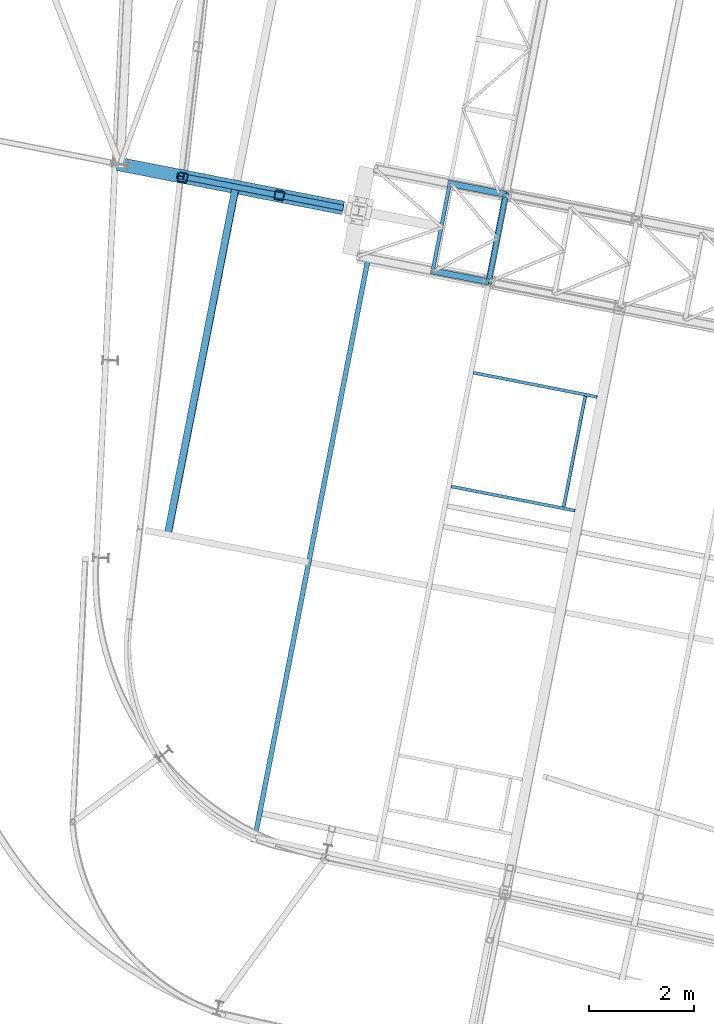
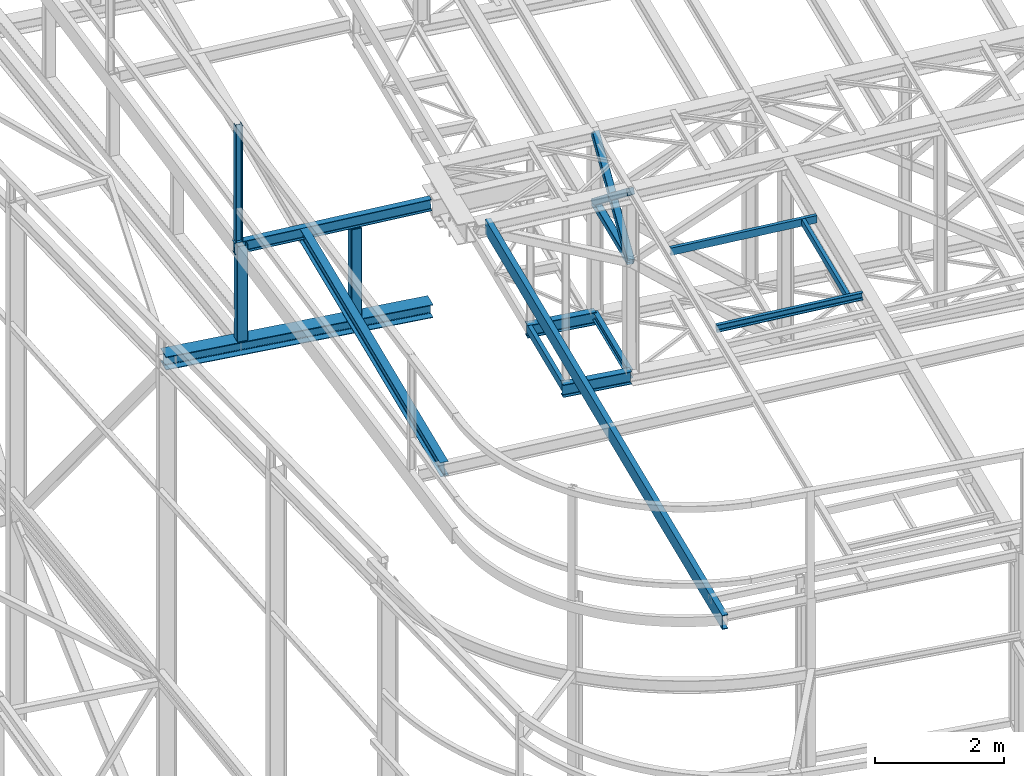
# One storey, part 40 of 215: 15 beams, 2 members, 17 elements without a shape of their own.
"""IFC2X3 building model written with IfcOpenShell, lengths in millimetres."""

from ifc_helpers import new_model, si_unit, frame, origin_with_axes, origin_2d_with_axis, place, context, subcontext, project, spatial, hollow_rectangle, i_section, u_section, extrude, material, type_object, element, aggregate, save


model = new_model("IFC2X3")

# Units and contexts
model_context = context("Model", 3, precision=1e-05, world=origin_with_axes())
body_context = subcontext(model_context, "Body", "Model", "MODEL_VIEW")
ifc_project = project(units=[si_unit("LENGTHUNIT", "METRE", prefix="MILLI"), si_unit("AREAUNIT", "SQUARE_METRE"), si_unit("VOLUMEUNIT", "CUBIC_METRE"), si_unit("MASSUNIT", "GRAM", prefix="KILO"), si_unit("TIMEUNIT", "SECOND"), si_unit("PLANEANGLEUNIT", "RADIAN"), si_unit("SOLIDANGLEUNIT", "STERADIAN"), si_unit("THERMODYNAMICTEMPERATUREUNIT", "DEGREE_CELSIUS"), si_unit("LUMINOUSINTENSITYUNIT", "LUMEN")], contexts=[model_context])

# Site, building, storey
site_placement = place(None, origin_with_axes())
site = spatial("IfcSite", under=ifc_project, at=site_placement, CompositionType="ELEMENT")
building_placement = place(site_placement, origin_with_axes())
building = spatial("IfcBuilding", under=site, at=building_placement, Name="Undefined", CompositionType="ELEMENT")
storey_placement = place(building_placement, origin_with_axes())
storey = spatial("IfcBuildingStorey", under=building, at=storey_placement, Name="Undefined", CompositionType="ELEMENT", Elevation=0.0)

# Assembly, beam
assembly_1_placement = place(storey_placement, origin_with_axes())
assembly_1 = element("IfcElementAssembly", 1, at=assembly_1_placement, inside=storey, Name="Steel Assembly", AssemblyPlace="NOTDEFINED", PredefinedType="RIGID_FRAME")
ifc_material_1 = material(Name="STEEL/S355JR")
beam_type_1 = type_object("IfcBeamType", Name="IPE240", PredefinedType="NOTDEFINED")
beam_1_placement = place(assembly_1_placement, frame((43625.947986334, 22043.2546402726, 8619.99999998952), z_axis=(0.0, 0.0, 1.0), x_axis=(0.981422409205525, -0.19185946604018, 1.89999991602007e-08)))
beam_1 = element("IfcBeam", 2, at=beam_1_placement, type_object=beam_type_1, material=ifc_material_1, ObjectType="IPE240", context=body_context, shape_type="SweptSolid", body=[
    extrude(i_section(OverallWidth=120.0, OverallDepth=240.0, WebThickness=6.199999809, FlangeThickness=9.800000191, FilletRadius=15.0, at=origin_2d_with_axis()), frame((1125.81204536132, 0.0, 0.0), z_axis=(-1.0, 0.0, 0.0), x_axis=(-6.93889390390723e-18, -1.0, -3.46944695195361e-18)), (0.0, 0.0, 1.0), 1125.8),
])
aggregate(assembly_1, [beam_1])

assembly_2_placement = place(storey_placement, origin_with_axes())
assembly_2 = element("IfcElementAssembly", 3, at=assembly_2_placement, inside=storey, Name="Steel Assembly", AssemblyPlace="NOTDEFINED", PredefinedType="RIGID_FRAME")
beam_2_placement = place(assembly_2_placement, frame((43952.1090785684, 23711.672735737, 8619.99999998888), z_axis=(0.0, 0.0, 1.0), x_axis=(0.981422409205525, -0.19185946604018, 1.89999991602007e-08)))
beam_2 = element("IfcBeam", 4, at=beam_2_placement, type_object=beam_type_1, material=ifc_material_1, ObjectType="IPE240", context=body_context, shape_type="SweptSolid", body=[
    extrude(i_section(OverallWidth=120.0, OverallDepth=240.0, WebThickness=6.199999809, FlangeThickness=9.800000191, FilletRadius=15.0, at=origin_2d_with_axis()), frame((1125.81204536132, 0.0, 0.0), z_axis=(-1.0, 0.0, 0.0), x_axis=(-6.93889390390723e-18, -1.0, -3.46944695195361e-18)), (0.0, 0.0, 1.0), 1125.8),
])
aggregate(assembly_2, [beam_2])

assembly_3_placement = place(storey_placement, origin_with_axes())
assembly_3 = element("IfcElementAssembly", 5, at=assembly_3_placement, inside=storey, Name="Steel Assembly", AssemblyPlace="NOTDEFINED", PredefinedType="RIGID_FRAME")
ifc_material_2 = material(Name="STEEL/S275JR")
beam_type_2 = type_object("IfcBeamType", Name="IPE270", PredefinedType="NOTDEFINED")
beam_3_placement = place(assembly_3_placement, frame((38609.0961091975, 17004.7103981775, 11917.5885771464), z_axis=(-0.0304080349967745, 0.00594450299936818, 0.999519891893966), x_axis=(0.191859470081235, 0.981422408415534, 0.0)))
beam_3 = element("IfcBeam", 6, at=beam_3_placement, type_object=beam_type_2, material=ifc_material_2, ObjectType="IPE270", context=body_context, shape_type="SweptSolid", body=[
    extrude(i_section(OverallWidth=135.0, OverallDepth=270.0, WebThickness=6.599999905, FlangeThickness=10.19999981, FilletRadius=15.0, at=origin_2d_with_axis()), frame((6759.39459620189, -3.7406013864434e-13, -1.82762251039334e-12), z_axis=(-1.0, 0.0, 0.0), x_axis=(-6.93889390390723e-18, -1.0, -3.46944695195361e-18)), (0.0, 0.0, 1.0), 6759.4),
])
aggregate(assembly_3, [beam_3])

assembly_4_placement = place(storey_placement, origin_with_axes())
assembly_4 = element("IfcElementAssembly", 7, at=assembly_4_placement, inside=storey, Name="Steel Assembly", AssemblyPlace="NOTDEFINED", PredefinedType="RIGID_FRAME")
beam_type_3 = type_object("IfcBeamType", PredefinedType="NOTDEFINED")
beam_4_placement = place(assembly_4_placement, frame((44730.8447938511, 21827.2570213611, 10796.0000011512), z_axis=(0.981422364268518, -0.191859461052493, -0.000300197000082615), x_axis=(0.191859470081235, 0.981422408415534, 0.0)))
beam_4 = element("IfcBeam", 8, at=beam_4_placement, type_object=beam_type_3, material=ifc_material_2, context=body_context, shape_type="SweptSolid", body=[
    extrude(hollow_rectangle(XDim=120.0, YDim=120.0, WallThickness=5.0, InnerFilletRadius=5.0, OuterFilletRadius=10.0, at=origin_2d_with_axis()), frame((1699.99999941724, 1.81898940354586e-12, 0.0), z_axis=(-1.0, 0.0, 0.0), x_axis=(-6.93889390390723e-18, -1.0, -3.46944695195361e-18)), (0.0, 0.0, 1.0), 1700.0),
])
aggregate(assembly_4, [beam_4])

assembly_5_placement = place(storey_placement, origin_with_axes())
assembly_5 = element("IfcElementAssembly", 9, at=assembly_5_placement, inside=storey, Name="Steel Assembly", AssemblyPlace="NOTDEFINED", PredefinedType="RIGID_FRAME")
ifc_material_3 = material(Name="STEEL/S235JR")
beam_type_4 = type_object("IfcBeamType", Name="UPN140", PredefinedType="NOTDEFINED")
beam_5_placement = place(assembly_5_placement, frame((46160.7311708302, 17536.3171577614, 12209.2147749676), z_axis=(-0.0304080349967745, 0.00594450299936818, 0.999519891893966), x_axis=(0.191879342079262, 0.981418523405397, 1.00000006478113e-09)))
beam_5 = element("IfcBeam", 10, at=beam_5_placement, type_object=beam_type_4, material=ifc_material_3, ObjectType="UPN140", context=body_context, shape_type="SweptSolid", body=[
    extrude(u_section(Depth=140.0, FlangeWidth=60.0, WebThickness=7.0, FlangeThickness=10.0, FilletRadius=10.0, EdgeRadius=5.0, FlangeSlope=0.0798299857122373, at=origin_2d_with_axis()), frame((2150.00349895753, 7.23853232835043e-12, -2.08044720554876e-15), z_axis=(-1.0, 0.0, 0.0), x_axis=(-6.93889390390723e-18, -1.0, -3.46944695195361e-18)), (0.0, 0.0, 1.0), 2150.0),
])
aggregate(assembly_5, [beam_5])

assembly_6_placement = place(storey_placement, origin_with_axes())
assembly_6 = element("IfcElementAssembly", 11, at=assembly_6_placement, inside=storey, Name="Steel Assembly", AssemblyPlace="NOTDEFINED", PredefinedType="RIGID_FRAME")
beam_6_placement = place(assembly_6_placement, frame((46798.1379311789, 19632.9744047019, 12216.1354340377), z_axis=(-0.0304080349967745, 0.00594450299936818, 0.999519891893966), x_axis=(-0.980947279001733, 0.191787511000338, -0.0309836480000548)))
beam_6 = element("IfcBeam", 12, at=beam_6_placement, type_object=beam_type_4, material=ifc_material_3, ObjectType="UPN140", context=body_context, shape_type="SweptSolid", body=[
    extrude(u_section(Depth=140.0, FlangeWidth=60.0, WebThickness=7.0, FlangeThickness=10.0, FilletRadius=10.0, EdgeRadius=5.0, FlangeSlope=0.0798299857122373, at=origin_2d_with_axis()), frame((2404.26612991932, -3.62067344519824e-12, -8.34147379613389e-15), z_axis=(-1.0, 0.0, 0.0), x_axis=(-6.93889390390723e-18, -1.0, -3.46944695195361e-18)), (0.0, 0.0, 1.0), 2404.3),
])
aggregate(assembly_6, [beam_6])

assembly_7_placement = place(storey_placement, origin_with_axes())
assembly_7 = element("IfcElementAssembly", 13, at=assembly_7_placement, inside=storey, Name="Steel Assembly", AssemblyPlace="NOTDEFINED", PredefinedType="RIGID_FRAME")
beam_7_placement = place(assembly_7_placement, frame((44015.7041884102, 17925.1288850211, 12141.6449800484), z_axis=(-0.0304080349967745, 0.00594450299936818, 0.999519891893966), x_axis=(0.9809472788136, -0.191787511963556, 0.0309836479941128)))
beam_7 = element("IfcBeam", 14, at=beam_7_placement, type_object=beam_type_4, material=ifc_material_3, ObjectType="UPN140", context=body_context, shape_type="SweptSolid", body=[
    extrude(u_section(Depth=140.0, FlangeWidth=60.0, WebThickness=7.0, FlangeThickness=10.0, FilletRadius=10.0, EdgeRadius=5.0, FlangeSlope=0.0798299857122373, at=origin_2d_with_axis()), frame((2404.26547487024, -4.76208710676447e-14, 1.81898940354586e-12), z_axis=(-1.0, 0.0, 0.0), x_axis=(-6.93889390390723e-18, -1.0, -3.46944695195361e-18)), (0.0, 0.0, 1.0), 2404.3),
])
aggregate(assembly_7, [beam_7])

# Assembly, member
assembly_8_placement = place(storey_placement, origin_with_axes())
assembly_8 = element("IfcElementAssembly", 15, at=assembly_8_placement, inside=storey, Name="Steel Assembly", AssemblyPlace="NOTDEFINED", PredefinedType="RIGID_FRAME")
member_type = type_object("IfcMemberType", PredefinedType="NOTDEFINED")
member_1_placement = place(assembly_8_placement, frame((45057.0058925501, 23495.6751151822, 10796.0000011494), z_axis=(0.981457773618154, -0.191678330925429, 0.000236765999907874), x_axis=(-0.15135681799229, -0.774238415960567, 0.614529078968702)))
member_1 = element("IfcMember", 16, at=member_1_placement, type_object=member_type, material=ifc_material_2, context=body_context, shape_type="SweptSolid", body=[
    extrude(hollow_rectangle(XDim=120.0, YDim=120.0, WallThickness=5.0, InnerFilletRadius=5.0, OuterFilletRadius=10.0, at=origin_2d_with_axis()), frame((2154.91514201782, 7.15633579384435e-12, 2.72186368544976e-14), z_axis=(-1.0, 0.0, 0.0), x_axis=(-6.93889390390723e-18, -1.0, -3.46944695195361e-18)), (0.0, 0.0, 1.0), 2154.9),
])
aggregate(assembly_8, [member_1])

assembly_9_placement = place(storey_placement, origin_with_axes())
assembly_9 = element("IfcElementAssembly", 17, at=assembly_9_placement, inside=storey, Name="Steel Assembly", AssemblyPlace="NOTDEFINED", PredefinedType="RIGID_FRAME")
member_2_placement = place(assembly_9_placement, frame((44730.8447938511, 21827.2570213611, 10796.0000011512), z_axis=(0.981457773617921, -0.191678330925384, -0.000236766999908156), x_axis=(0.151356816942679, 0.774238418706794, 0.614529075767276)))
member_2 = element("IfcMember", 18, at=member_2_placement, type_object=member_type, material=ifc_material_2, context=body_context, shape_type="SweptSolid", body=[
    extrude(hollow_rectangle(XDim=120.0, YDim=120.0, WallThickness=5.0, InnerFilletRadius=5.0, OuterFilletRadius=10.0, at=origin_2d_with_axis()), frame((2154.91514201782, 7.15633579384435e-12, 2.72186368544976e-14), z_axis=(-1.0, 0.0, 0.0), x_axis=(-6.93889390390723e-18, -1.0, -3.46944695195361e-18)), (0.0, 0.0, 1.0), 2154.9),
])
aggregate(assembly_9, [member_2])

# Assembly, beam
assembly_10_placement = place(storey_placement, origin_with_axes())
assembly_10 = element("IfcElementAssembly", 19, at=assembly_10_placement, inside=storey, Name="Steel Assembly", AssemblyPlace="NOTDEFINED", PredefinedType="RIGID_FRAME")
beam_type_5 = type_object("IfcBeamType", PredefinedType="NOTDEFINED")
beam_8_placement = place(assembly_10_placement, frame((38894.1289178331, 23820.7387843003, 11978.1959568967), z_axis=(-0.981422412140383, 0.191859451027444, 0.0), x_axis=(0.0, 0.0, -1.0)))
beam_8 = element("IfcBeam", 20, at=beam_8_placement, type_object=beam_type_5, material=ifc_material_2, Name="MONTANT", context=body_context, shape_type="SweptSolid", body=[
    extrude(hollow_rectangle(XDim=180.0, YDim=180.0, WallThickness=8.0, InnerFilletRadius=12.0, OuterFilletRadius=20.0, at=origin_2d_with_axis()), frame((1804.90053736603, 0.0, 0.0), z_axis=(-1.0, 0.0, 0.0), x_axis=(-6.93889390390723e-18, -1.0, -3.46944695195361e-18)), (0.0, 0.0, 1.0), 1804.9),
])
aggregate(assembly_10, [beam_8])

assembly_11_placement = place(storey_placement, origin_with_axes())
assembly_11 = element("IfcElementAssembly", 21, at=assembly_11_placement, inside=storey, Name="Steel Assembly", AssemblyPlace="NOTDEFINED", PredefinedType="RIGID_FRAME")
beam_9_placement = place(assembly_11_placement, frame((40737.2278874188, 23476.6761061621, 11861.5971783919), z_axis=(-0.981422411745904, 0.191859450950327, -2.83529999923565e-05), x_axis=(2.78279999885813e-05, -5.4329999982362e-06, -0.999999999598043)))
beam_9 = element("IfcBeam", 22, at=beam_9_placement, type_object=beam_type_5, material=ifc_material_2, Name="MONTANT", context=body_context, shape_type="SweptSolid", body=[
    extrude(hollow_rectangle(XDim=180.0, YDim=180.0, WallThickness=8.0, InnerFilletRadius=12.0, OuterFilletRadius=20.0, at=origin_2d_with_axis()), frame((1688.30175973813, -1.90905717134714e-18, 5.72018886162244e-18), z_axis=(-1.0, 0.0, 0.0), x_axis=(-6.93889390390723e-18, -1.0, -3.46944695195361e-18)), (0.0, 0.0, 1.0), 1688.3),
])
aggregate(assembly_11, [beam_9])

assembly_12_placement = place(storey_placement, origin_with_axes())
assembly_12 = element("IfcElementAssembly", 23, at=assembly_12_placement, inside=storey, Name="Steel Assembly", AssemblyPlace="NOTDEFINED", PredefinedType="RIGID_FRAME")
beam_type_6 = type_object("IfcBeamType", Name="HEA120", PredefinedType="NOTDEFINED")
beam_10_placement = place(assembly_12_placement, frame((38861.2309280686, 23842.8824790081, 14219.9969942323), z_axis=(0.981422409205525, -0.19185946604018, 1.89999991602007e-08), x_axis=(0.0, 0.0, -1.0)))
beam_10 = element("IfcBeam", 24, at=beam_10_placement, type_object=beam_type_6, material=ifc_material_2, ObjectType="HEA120", context=body_context, shape_type="SweptSolid", body=[
    extrude(i_section(OverallWidth=120.0, OverallDepth=114.0, WebThickness=5.0, FlangeThickness=8.0, FilletRadius=12.0, at=origin_2d_with_axis()), frame((2200.57697439858, -7.28109843861241e-21, -1.45621968772248e-20), z_axis=(-1.0, 0.0, 0.0), x_axis=(-6.93889390390723e-18, -1.0, -3.46944695195361e-18)), (0.0, 0.0, 1.0), 2200.6),
])
aggregate(assembly_12, [beam_10])

assembly_13_placement = place(storey_placement, origin_with_axes())
assembly_13 = element("IfcElementAssembly", 25, at=assembly_13_placement, inside=storey, Name="Steel Assembly", AssemblyPlace="NOTDEFINED", PredefinedType="RIGID_FRAME")
beam_type_7 = type_object("IfcBeamType", Name="IPE220", PredefinedType="NOTDEFINED")
beam_11_placement = place(assembly_13_placement, frame((38785.5199345108, 23857.5884021113, 11907.2183713005), z_axis=(-0.0304080349967745, 0.00594450299936818, 0.999519891893966), x_axis=(0.980946258798752, -0.191792730960652, 0.0309836359936435)))
beam_11 = element("IfcBeam", 26, at=beam_11_placement, type_object=beam_type_7, material=ifc_material_2, Name="POUTRE", ObjectType="IPE220", context=body_context, shape_type="SweptSolid", body=[
    extrude(i_section(OverallWidth=110.0, OverallDepth=220.0, WebThickness=5.900000095, FlangeThickness=9.199999809, FilletRadius=12.0, at=origin_2d_with_axis()), frame((3235.80858166054, 3.66863354280914e-12, 1.80776293732511e-12), z_axis=(-1.0, 0.0, 0.0), x_axis=(-6.93889390390723e-18, -1.0, -3.46944695195361e-18)), (0.0, 0.0, 1.0), 3235.8),
])
aggregate(assembly_13, [beam_11])

assembly_14_placement = place(storey_placement, origin_with_axes())
assembly_14 = element("IfcElementAssembly", 27, at=assembly_14_placement, inside=storey, Name="Steel Assembly", AssemblyPlace="NOTDEFINED", PredefinedType="RIGID_FRAME")
beam_type_8 = type_object("IfcBeamType", Name="UPE160", PredefinedType="NOTDEFINED")
beam_12_placement = place(assembly_14_placement, frame((43660.3018631942, 22036.5387590096, 8659.90778501801), z_axis=(0.0, 0.0, 1.0), x_axis=(0.191859470081235, 0.981422408415534, 0.0)))
beam_12 = element("IfcBeam", 28, at=beam_12_placement, type_object=beam_type_8, material=ifc_material_2, ObjectType="UPE160", context=body_context, shape_type="SweptSolid", body=[
    extrude(u_section(Depth=160.0, FlangeWidth=70.0, WebThickness=5.5, FlangeThickness=9.5, FilletRadius=12.0, at=origin_2d_with_axis()), frame((1699.99999941724, 1.81898940354586e-12, 0.0), z_axis=(-1.0, 0.0, 0.0), x_axis=(-6.93889390390723e-18, -1.0, -3.46944695195361e-18)), (0.0, 0.0, 1.0), 1700.0),
])
aggregate(assembly_14, [beam_12])

assembly_15_placement = place(storey_placement, origin_with_axes())
assembly_15 = element("IfcElementAssembly", 29, at=assembly_15_placement, inside=storey, Name="Steel Assembly", AssemblyPlace="NOTDEFINED", PredefinedType="RIGID_FRAME")
beam_type_9 = type_object("IfcBeamType", Name="UPE270", PredefinedType="NOTDEFINED")
beam_13_placement = place(assembly_15_placement, frame((40253.3170382938, 11136.3765569843, 12001.103626676), z_axis=(0.0, 0.0, 1.0), x_axis=(0.191859470081235, 0.981422408415534, 0.0)))
beam_13 = element("IfcBeam", 30, at=beam_13_placement, type_object=beam_type_9, material=ifc_material_2, ObjectType="UPE270", context=body_context, shape_type="SweptSolid", body=[
    extrude(u_section(Depth=270.0, FlangeWidth=95.0, WebThickness=7.5, FlangeThickness=13.5, FilletRadius=15.0, at=origin_2d_with_axis()), frame((11351.3257214102, 3.15062579398235e-13, 0.0), z_axis=(-1.0, 0.0, 0.0), x_axis=(-6.93889390390723e-18, -1.0, -3.46944695195361e-18)), (0.0, 0.0, 1.0), 11351.3),
])
aggregate(assembly_15, [beam_13])

assembly_16_placement = place(storey_placement, origin_with_axes())
assembly_16 = element("IfcElementAssembly", 31, at=assembly_16_placement, inside=storey, Name="Steel Assembly", AssemblyPlace="NOTDEFINED", PredefinedType="RIGID_FRAME")
beam_type_10 = type_object("IfcBeamType", Name="HEA260", PredefinedType="NOTDEFINED")
beam_14_placement = place(assembly_16_placement, frame((37650.7468338012, 24079.3381068405, 10048.2954195188), z_axis=(0.0, 0.0, 1.0), x_axis=(0.981422409205525, -0.19185946604018, 1.89999991602007e-08)))
beam_14 = element("IfcBeam", 32, at=beam_14_placement, type_object=beam_type_10, material=ifc_material_2, Name="POUTRE", ObjectType="HEA260", context=body_context, shape_type="SweptSolid", body=[
    extrude(i_section(OverallWidth=260.0, OverallDepth=250.0, WebThickness=7.5, FlangeThickness=12.5, FilletRadius=24.0, at=origin_2d_with_axis()), frame((4387.06545741555, 0.0, 0.0), z_axis=(-1.0, 0.0, 0.0), x_axis=(-6.93889390390723e-18, -1.0, -3.46944695195361e-18)), (0.0, 0.0, 1.0), 4387.1),
])
aggregate(assembly_16, [beam_14])

assembly_17_placement = place(storey_placement, origin_with_axes())
assembly_17 = element("IfcElementAssembly", 33, at=assembly_17_placement, inside=storey, Name="Steel Assembly", AssemblyPlace="NOTDEFINED", PredefinedType="RIGID_FRAME")
beam_type_11 = type_object("IfcBeamType", Name="IPE160", PredefinedType="NOTDEFINED")
beam_15_placement = place(assembly_17_placement, frame((44730.8451557729, 21827.2569424026, 8650.0), z_axis=(0.0, 0.0, 1.0), x_axis=(0.191859470081235, 0.981422408415534, 0.0)))
beam_15 = element("IfcBeam", 34, at=beam_15_placement, type_object=beam_type_11, material=ifc_material_2, ObjectType="IPE160", context=body_context, shape_type="SweptSolid", body=[
    extrude(i_section(OverallWidth=82.0, OverallDepth=160.0, WebThickness=5.0, FlangeThickness=7.400000095, FilletRadius=9.0, at=origin_2d_with_axis()), frame((1699.99999941724, 1.81898940354586e-12, 0.0), z_axis=(-1.0, 0.0, 0.0), x_axis=(-6.93889390390723e-18, -1.0, -3.46944695195361e-18)), (0.0, 0.0, 1.0), 1700.0),
])
aggregate(assembly_17, [beam_15])

save(model, "model.ifc")
